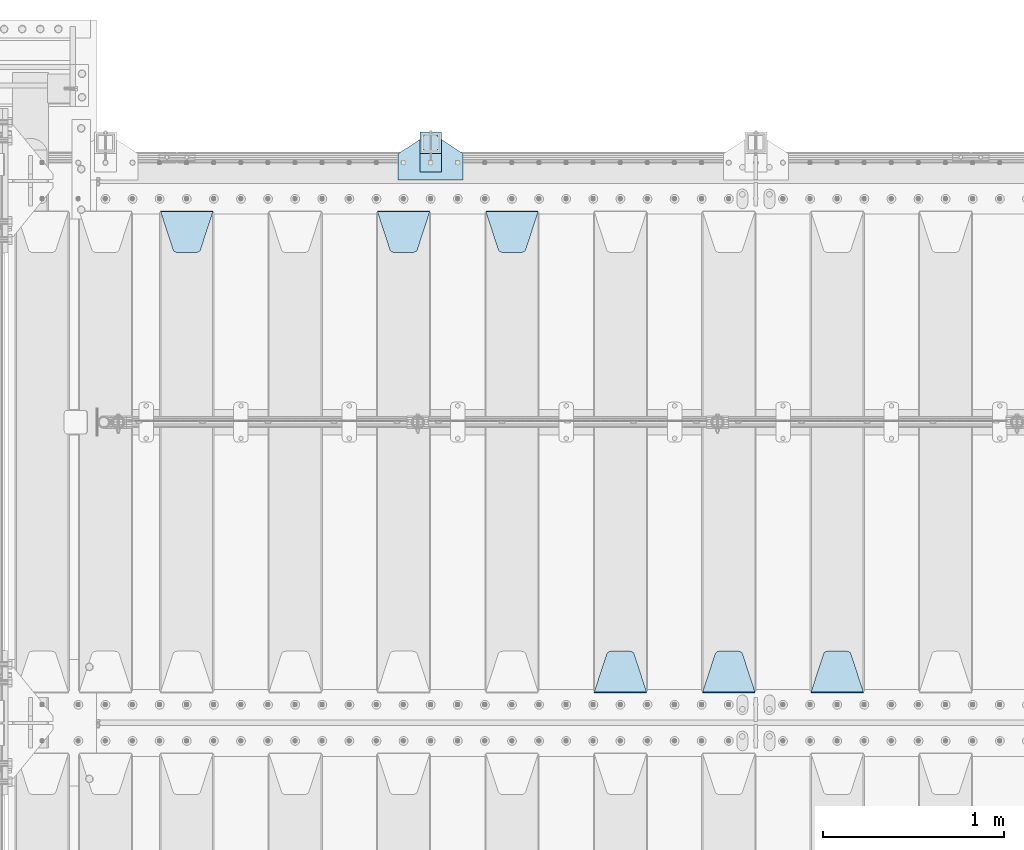
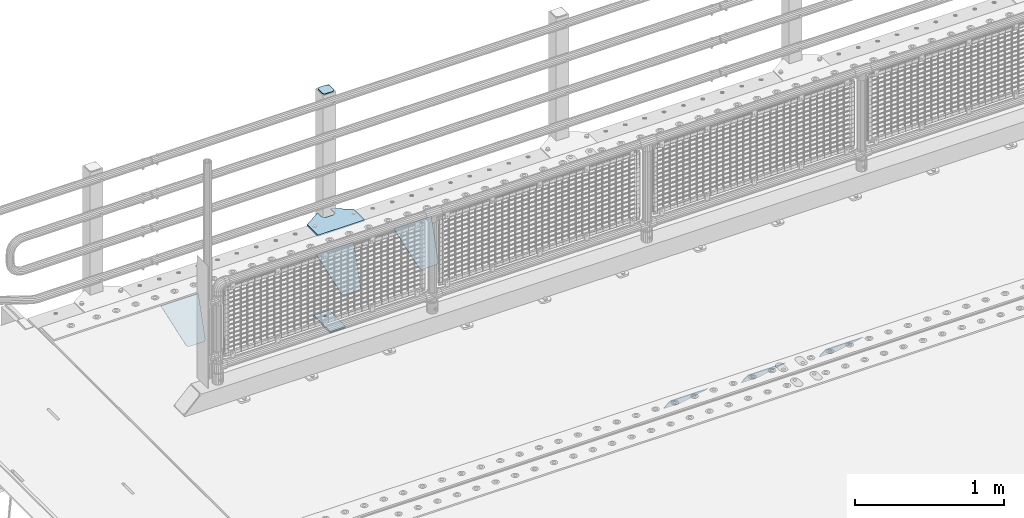
# One storey, part 160 of 193: 10 plates.
"""IFC2X3 building model written with IfcOpenShell, lengths in millimetres."""

from ifc_helpers import new_model, si_unit, frame, origin_with_axes, place, context, subcontext, project, spatial, faceted_brep, material, type_object, element, save


model = new_model("IFC2X3")

# Units and contexts
model_context = context("Model", 3, precision=1e-05, world=origin_with_axes())
body_context = subcontext(model_context, "Body", "Model", "MODEL_VIEW")
ifc_project = project(units=[si_unit("LENGTHUNIT", "METRE", prefix="MILLI"), si_unit("AREAUNIT", "SQUARE_METRE"), si_unit("VOLUMEUNIT", "CUBIC_METRE"), si_unit("MASSUNIT", "GRAM", prefix="KILO"), si_unit("TIMEUNIT", "SECOND"), si_unit("PLANEANGLEUNIT", "RADIAN"), si_unit("SOLIDANGLEUNIT", "STERADIAN"), si_unit("THERMODYNAMICTEMPERATUREUNIT", "DEGREE_CELSIUS"), si_unit("LUMINOUSINTENSITYUNIT", "LUMEN")], contexts=[model_context])

# Site, building, storey
site_placement = place(None, origin_with_axes())
site = spatial("IfcSite", under=ifc_project, at=site_placement, CompositionType="ELEMENT")
building_placement = place(site_placement, origin_with_axes())
building = spatial("IfcBuilding", under=site, at=building_placement, Name="Standard", CompositionType="ELEMENT")
storey_placement = place(building_placement, origin_with_axes())
storey = spatial("IfcBuildingStorey", under=building, at=storey_placement, Name="Undefined", CompositionType="ELEMENT", Elevation=0.0)

# Plates
ifc_material_1 = material(Name="STEEL/S355N")
plate_type_1 = type_object("IfcPlateType", PredefinedType="NOTDEFINED")
plate_1_placement = place(storey_placement, frame((-37705.0, 27168.232233047, -1.76776695296758), z_axis=(0.0, 0.707106781186547, -0.707106781186548), x_axis=(-1.0, 0.0, 0.0)))
element("IfcPlate", 1, at=plate_1_placement, inside=storey, type_object=plate_type_1, material=ifc_material_1, context=body_context, shape_type="Brep", body=[
    faceted_brep([(0.0, -2.5, 0.0), (69.345504679477, -2.50000000000364, 300.171731424831), (69.345504679477, 2.49999999999636, 300.171731424831), (0.0, 2.5, 0.0), (70.9274061199576, -2.50000000000364, 304.897442415397), (70.9274061199576, 2.49999999999636, 304.897442415397), (73.3818627772307, -2.50000000000364, 309.234538108529), (73.3818627772307, 2.49999999999636, 309.234538108529), (76.6187032999551, -2.50000000000728, 313.023683126103), (76.6187032999551, 2.49999999999636, 313.023683126103), (80.5190132704993, -2.50000000000364, 316.125672595372), (80.5190132704993, 2.49999999999636, 316.125672595368), (84.9395038596849, -2.50000000000364, 318.426546230472), (84.9395038596849, 2.49999999999636, 318.426546230476), (89.7177759439219, -2.50000000000364, 319.841774983273), (89.7177759439219, 2.49999999999636, 319.841774983277), (94.678286292652, -2.50000000000364, 320.319366455074), (94.678286292652, 2.49999999999636, 320.319366455074), (195.321713707348, -2.50000000000364, 320.319366455074), (195.321713707348, 2.49999999999636, 320.319366455074), (200.282224056078, -2.50000000000364, 319.841774983273), (200.282224056078, 2.49999999999636, 319.841774983277), (205.060496140315, -2.50000000000364, 318.426546230472), (205.060496140315, 2.49999999999636, 318.426546230472), (209.480986729501, -2.50000000000364, 316.125672595372), (209.480986729501, 2.49999999999636, 316.125672595368), (213.381296700045, -2.50000000000728, 313.023683126103), (213.381296700045, 2.49999999999272, 313.023683126103), (216.618137222769, -2.50000000000364, 309.234538108525), (216.618137222769, 2.49999999999636, 309.234538108522), (219.072593880042, -2.50000000000364, 304.897442415397), (219.072593880042, 2.49999999999636, 304.897442415397), (220.654495320523, -2.50000000000364, 300.171731424831), (220.654495320523, 2.49999999999636, 300.171731424831), (290.0, -2.50000000000364, 0.0), (290.0, 2.49999999999636, 0.0)], [[[0, 1, 2, 3]], [[1, 4, 5, 2]], [[4, 6, 7, 5]], [[6, 8, 9, 7]], [[8, 10, 11, 9]], [[10, 12, 13, 11]], [[12, 14, 15, 13]], [[14, 16, 17, 15]], [[16, 18, 19, 17]], [[18, 20, 21, 19]], [[20, 22, 23, 21]], [[22, 24, 25, 23]], [[24, 26, 27, 25]], [[26, 28, 29, 27]], [[28, 30, 31, 29]], [[30, 32, 33, 31]], [[32, 34, 35, 33]], [[34, 0, 3, 35]], [[5, 7, 9, 11, 13, 15, 17, 19, 21, 23, 25, 27, 29, 31, 33, 35, 3, 2]], [[34, 32, 30, 28, 26, 24, 22, 20, 18, 16, 14, 12, 10, 8, 6, 4, 1, 0]]]),
])
plate_2_placement = place(storey_placement, frame((-38305.0, 27168.232233047, -1.76776695296758), z_axis=(0.0, 0.707106781186547, -0.707106781186548), x_axis=(-1.0, 0.0, 0.0)))
element("IfcPlate", 2, at=plate_2_placement, inside=storey, type_object=plate_type_1, material=ifc_material_1, context=body_context, shape_type="Brep", body=[
    faceted_brep([(0.0, -2.5, 0.0), (69.345504679477, -2.50000000000364, 300.171731424831), (69.345504679477, 2.49999999999636, 300.171731424831), (0.0, 2.5, 0.0), (70.9274061199576, -2.50000000000364, 304.897442415397), (70.9274061199576, 2.49999999999636, 304.897442415397), (73.3818627772307, -2.50000000000364, 309.234538108529), (73.3818627772307, 2.49999999999636, 309.234538108529), (76.6187032999551, -2.50000000000728, 313.023683126103), (76.6187032999551, 2.49999999999636, 313.023683126103), (80.5190132704993, -2.50000000000364, 316.125672595372), (80.5190132704993, 2.49999999999636, 316.125672595368), (84.9395038596849, -2.50000000000364, 318.426546230472), (84.9395038596849, 2.49999999999636, 318.426546230476), (89.7177759439219, -2.50000000000364, 319.841774983273), (89.7177759439219, 2.49999999999636, 319.841774983277), (94.678286292652, -2.50000000000364, 320.319366455074), (94.678286292652, 2.49999999999636, 320.319366455074), (195.321713707348, -2.50000000000364, 320.319366455074), (195.321713707348, 2.49999999999636, 320.319366455074), (200.282224056078, -2.50000000000364, 319.841774983273), (200.282224056078, 2.49999999999636, 319.841774983277), (205.060496140315, -2.50000000000364, 318.426546230472), (205.060496140315, 2.49999999999636, 318.426546230472), (209.480986729501, -2.50000000000364, 316.125672595372), (209.480986729501, 2.49999999999636, 316.125672595368), (213.381296700045, -2.50000000000728, 313.023683126103), (213.381296700045, 2.49999999999272, 313.023683126103), (216.618137222769, -2.50000000000364, 309.234538108525), (216.618137222769, 2.49999999999636, 309.234538108522), (219.072593880042, -2.50000000000364, 304.897442415397), (219.072593880042, 2.49999999999636, 304.897442415397), (220.654495320523, -2.50000000000364, 300.171731424831), (220.654495320523, 2.49999999999636, 300.171731424831), (290.0, -2.50000000000364, 0.0), (290.0, 2.49999999999636, 0.0)], [[[0, 1, 2, 3]], [[1, 4, 5, 2]], [[4, 6, 7, 5]], [[6, 8, 9, 7]], [[8, 10, 11, 9]], [[10, 12, 13, 11]], [[12, 14, 15, 13]], [[14, 16, 17, 15]], [[16, 18, 19, 17]], [[18, 20, 21, 19]], [[20, 22, 23, 21]], [[22, 24, 25, 23]], [[24, 26, 27, 25]], [[26, 28, 29, 27]], [[28, 30, 31, 29]], [[30, 32, 33, 31]], [[32, 34, 35, 33]], [[34, 0, 3, 35]], [[5, 7, 9, 11, 13, 15, 17, 19, 21, 23, 25, 27, 29, 31, 33, 35, 3, 2]], [[34, 32, 30, 28, 26, 24, 22, 20, 18, 16, 14, 12, 10, 8, 6, 4, 1, 0]]]),
])
plate_3_placement = place(storey_placement, frame((-38905.0, 27168.232233047, -1.76776695296758), z_axis=(0.0, 0.707106781186547, -0.707106781186548), x_axis=(-1.0, 0.0, 0.0)))
element("IfcPlate", 3, at=plate_3_placement, inside=storey, type_object=plate_type_1, material=ifc_material_1, context=body_context, shape_type="Brep", body=[
    faceted_brep([(0.0, -2.5, 0.0), (69.345504679477, -2.50000000000364, 300.171731424831), (69.345504679477, 2.49999999999636, 300.171731424831), (0.0, 2.5, 0.0), (70.9274061199576, -2.50000000000364, 304.897442415397), (70.9274061199576, 2.49999999999636, 304.897442415397), (73.3818627772307, -2.50000000000364, 309.234538108529), (73.3818627772307, 2.49999999999636, 309.234538108529), (76.6187032999551, -2.50000000000728, 313.023683126103), (76.6187032999551, 2.49999999999636, 313.023683126103), (80.5190132704993, -2.50000000000364, 316.125672595372), (80.5190132704993, 2.49999999999636, 316.125672595368), (84.9395038596849, -2.50000000000364, 318.426546230472), (84.9395038596849, 2.49999999999636, 318.426546230476), (89.7177759439219, -2.50000000000364, 319.841774983273), (89.7177759439219, 2.49999999999636, 319.841774983277), (94.678286292652, -2.50000000000364, 320.319366455074), (94.678286292652, 2.49999999999636, 320.319366455074), (195.321713707348, -2.50000000000364, 320.319366455074), (195.321713707348, 2.49999999999636, 320.319366455074), (200.282224056078, -2.50000000000364, 319.841774983273), (200.282224056078, 2.49999999999636, 319.841774983277), (205.060496140315, -2.50000000000364, 318.426546230472), (205.060496140315, 2.49999999999636, 318.426546230472), (209.480986729501, -2.50000000000364, 316.125672595372), (209.480986729501, 2.49999999999636, 316.125672595368), (213.381296700045, -2.50000000000728, 313.023683126103), (213.381296700045, 2.49999999999272, 313.023683126103), (216.618137222769, -2.50000000000364, 309.234538108525), (216.618137222769, 2.49999999999636, 309.234538108522), (219.072593880042, -2.50000000000364, 304.897442415397), (219.072593880042, 2.49999999999636, 304.897442415397), (220.654495320523, -2.50000000000364, 300.171731424831), (220.654495320523, 2.49999999999636, 300.171731424831), (290.0, -2.50000000000364, 0.0), (290.0, 2.49999999999636, 0.0)], [[[0, 1, 2, 3]], [[1, 4, 5, 2]], [[4, 6, 7, 5]], [[6, 8, 9, 7]], [[8, 10, 11, 9]], [[10, 12, 13, 11]], [[12, 14, 15, 13]], [[14, 16, 17, 15]], [[16, 18, 19, 17]], [[18, 20, 21, 19]], [[20, 22, 23, 21]], [[22, 24, 25, 23]], [[24, 26, 27, 25]], [[26, 28, 29, 27]], [[28, 30, 31, 29]], [[30, 32, 33, 31]], [[32, 34, 35, 33]], [[34, 0, 3, 35]], [[5, 7, 9, 11, 13, 15, 17, 19, 21, 23, 25, 27, 29, 31, 33, 35, 3, 2]], [[34, 32, 30, 28, 26, 24, 22, 20, 18, 16, 14, 12, 10, 8, 6, 4, 1, 0]]]),
])
plate_4_placement = place(storey_placement, frame((-39795.0, 29831.767766956, -1.76776695296758), z_axis=(0.0, -0.707106781186547, -0.707106781186548), x_axis=(1.0, 0.0, 0.0)))
element("IfcPlate", 4, at=plate_4_placement, inside=storey, type_object=plate_type_1, material=ifc_material_1, context=body_context, shape_type="Brep", body=[
    faceted_brep([(0.0, -2.5, 0.0), (69.345504679477, -2.50000000000364, 300.171731424831), (69.345504679477, 2.49999999999636, 300.171731424831), (0.0, 2.5, 0.0), (70.9274061199576, -2.50000000000364, 304.897442415397), (70.9274061199576, 2.49999999999636, 304.897442415397), (73.3818627772307, -2.50000000000364, 309.234538108529), (73.3818627772307, 2.49999999999636, 309.234538108529), (76.6187032999551, -2.50000000000728, 313.023683126103), (76.6187032999551, 2.49999999999636, 313.023683126103), (80.5190132704993, -2.50000000000364, 316.125672595372), (80.5190132704993, 2.49999999999636, 316.125672595368), (84.9395038596849, -2.50000000000364, 318.426546230472), (84.9395038596849, 2.49999999999636, 318.426546230476), (89.7177759439219, -2.50000000000364, 319.841774983273), (89.7177759439219, 2.49999999999636, 319.841774983277), (94.678286292652, -2.50000000000364, 320.319366455074), (94.678286292652, 2.49999999999636, 320.319366455074), (195.321713707348, -2.50000000000364, 320.319366455074), (195.321713707348, 2.49999999999636, 320.319366455074), (200.282224056078, -2.50000000000364, 319.841774983273), (200.282224056078, 2.49999999999636, 319.841774983277), (205.060496140315, -2.50000000000364, 318.426546230472), (205.060496140315, 2.49999999999636, 318.426546230472), (209.480986729501, -2.50000000000364, 316.125672595372), (209.480986729501, 2.49999999999636, 316.125672595368), (213.381296700045, -2.50000000000728, 313.023683126103), (213.381296700045, 2.49999999999272, 313.023683126103), (216.618137222769, -2.50000000000364, 309.234538108525), (216.618137222769, 2.49999999999636, 309.234538108522), (219.072593880042, -2.50000000000364, 304.897442415397), (219.072593880042, 2.49999999999636, 304.897442415397), (220.654495320523, -2.50000000000364, 300.171731424831), (220.654495320523, 2.49999999999636, 300.171731424831), (290.0, -2.50000000000364, 0.0), (290.0, 2.49999999999636, 0.0)], [[[0, 1, 2, 3]], [[1, 4, 5, 2]], [[4, 6, 7, 5]], [[6, 8, 9, 7]], [[8, 10, 11, 9]], [[10, 12, 13, 11]], [[12, 14, 15, 13]], [[14, 16, 17, 15]], [[16, 18, 19, 17]], [[18, 20, 21, 19]], [[20, 22, 23, 21]], [[22, 24, 25, 23]], [[24, 26, 27, 25]], [[26, 28, 29, 27]], [[28, 30, 31, 29]], [[30, 32, 33, 31]], [[32, 34, 35, 33]], [[34, 0, 3, 35]], [[5, 7, 9, 11, 13, 15, 17, 19, 21, 23, 25, 27, 29, 31, 33, 35, 3, 2]], [[34, 32, 30, 28, 26, 24, 22, 20, 18, 16, 14, 12, 10, 8, 6, 4, 1, 0]]]),
])
plate_5_placement = place(storey_placement, frame((-40395.0, 29831.767766956, -1.76776695296758), z_axis=(0.0, -0.707106781186547, -0.707106781186548), x_axis=(1.0, 0.0, 0.0)))
element("IfcPlate", 5, at=plate_5_placement, inside=storey, type_object=plate_type_1, material=ifc_material_1, context=body_context, shape_type="Brep", body=[
    faceted_brep([(0.0, -2.5, 0.0), (69.345504679477, -2.50000000000364, 300.171731424831), (69.345504679477, 2.49999999999636, 300.171731424831), (0.0, 2.5, 0.0), (70.9274061199576, -2.50000000000364, 304.897442415397), (70.9274061199576, 2.49999999999636, 304.897442415397), (73.3818627772307, -2.50000000000364, 309.234538108529), (73.3818627772307, 2.49999999999636, 309.234538108529), (76.6187032999551, -2.50000000000728, 313.023683126103), (76.6187032999551, 2.49999999999636, 313.023683126103), (80.5190132704993, -2.50000000000364, 316.125672595372), (80.5190132704993, 2.49999999999636, 316.125672595368), (84.9395038596849, -2.50000000000364, 318.426546230472), (84.9395038596849, 2.49999999999636, 318.426546230476), (89.7177759439219, -2.50000000000364, 319.841774983273), (89.7177759439219, 2.49999999999636, 319.841774983277), (94.678286292652, -2.50000000000364, 320.319366455074), (94.678286292652, 2.49999999999636, 320.319366455074), (195.321713707348, -2.50000000000364, 320.319366455074), (195.321713707348, 2.49999999999636, 320.319366455074), (200.282224056078, -2.50000000000364, 319.841774983273), (200.282224056078, 2.49999999999636, 319.841774983277), (205.060496140315, -2.50000000000364, 318.426546230472), (205.060496140315, 2.49999999999636, 318.426546230472), (209.480986729501, -2.50000000000364, 316.125672595372), (209.480986729501, 2.49999999999636, 316.125672595368), (213.381296700045, -2.50000000000728, 313.023683126103), (213.381296700045, 2.49999999999272, 313.023683126103), (216.618137222769, -2.50000000000364, 309.234538108525), (216.618137222769, 2.49999999999636, 309.234538108522), (219.072593880042, -2.50000000000364, 304.897442415397), (219.072593880042, 2.49999999999636, 304.897442415397), (220.654495320523, -2.50000000000364, 300.171731424831), (220.654495320523, 2.49999999999636, 300.171731424831), (290.0, -2.50000000000364, 0.0), (290.0, 2.49999999999636, 0.0)], [[[0, 1, 2, 3]], [[1, 4, 5, 2]], [[4, 6, 7, 5]], [[6, 8, 9, 7]], [[8, 10, 11, 9]], [[10, 12, 13, 11]], [[12, 14, 15, 13]], [[14, 16, 17, 15]], [[16, 18, 19, 17]], [[18, 20, 21, 19]], [[20, 22, 23, 21]], [[22, 24, 25, 23]], [[24, 26, 27, 25]], [[26, 28, 29, 27]], [[28, 30, 31, 29]], [[30, 32, 33, 31]], [[32, 34, 35, 33]], [[34, 0, 3, 35]], [[5, 7, 9, 11, 13, 15, 17, 19, 21, 23, 25, 27, 29, 31, 33, 35, 3, 2]], [[34, 32, 30, 28, 26, 24, 22, 20, 18, 16, 14, 12, 10, 8, 6, 4, 1, 0]]]),
])
plate_6_placement = place(storey_placement, frame((-41595.0, 29831.767766956, -1.76776695296758), z_axis=(0.0, -0.707106781186547, -0.707106781186548), x_axis=(1.0, 0.0, 0.0)))
element("IfcPlate", 6, at=plate_6_placement, inside=storey, type_object=plate_type_1, material=ifc_material_1, context=body_context, shape_type="Brep", body=[
    faceted_brep([(0.0, -2.5, 0.0), (69.345504679477, -2.50000000000364, 300.171731424831), (69.345504679477, 2.49999999999636, 300.171731424831), (0.0, 2.5, 0.0), (70.9274061199576, -2.50000000000364, 304.897442415397), (70.9274061199576, 2.49999999999636, 304.897442415397), (73.3818627772307, -2.50000000000364, 309.234538108529), (73.3818627772307, 2.49999999999636, 309.234538108529), (76.6187032999551, -2.50000000000728, 313.023683126103), (76.6187032999551, 2.49999999999636, 313.023683126103), (80.5190132704993, -2.50000000000364, 316.125672595372), (80.5190132704993, 2.49999999999636, 316.125672595368), (84.9395038596849, -2.50000000000364, 318.426546230472), (84.9395038596849, 2.49999999999636, 318.426546230476), (89.7177759439219, -2.50000000000364, 319.841774983273), (89.7177759439219, 2.49999999999636, 319.841774983277), (94.678286292652, -2.50000000000364, 320.319366455074), (94.678286292652, 2.49999999999636, 320.319366455074), (195.321713707348, -2.50000000000364, 320.319366455074), (195.321713707348, 2.49999999999636, 320.319366455074), (200.282224056078, -2.50000000000364, 319.841774983273), (200.282224056078, 2.49999999999636, 319.841774983277), (205.060496140315, -2.50000000000364, 318.426546230472), (205.060496140315, 2.49999999999636, 318.426546230472), (209.480986729501, -2.50000000000364, 316.125672595372), (209.480986729501, 2.49999999999636, 316.125672595368), (213.381296700045, -2.50000000000728, 313.023683126103), (213.381296700045, 2.49999999999272, 313.023683126103), (216.618137222769, -2.50000000000364, 309.234538108525), (216.618137222769, 2.49999999999636, 309.234538108522), (219.072593880042, -2.50000000000364, 304.897442415397), (219.072593880042, 2.49999999999636, 304.897442415397), (220.654495320523, -2.50000000000364, 300.171731424831), (220.654495320523, 2.49999999999636, 300.171731424831), (290.0, -2.50000000000364, 0.0), (290.0, 2.49999999999636, 0.0)], [[[0, 1, 2, 3]], [[1, 4, 5, 2]], [[4, 6, 7, 5]], [[6, 8, 9, 7]], [[8, 10, 11, 9]], [[10, 12, 13, 11]], [[12, 14, 15, 13]], [[14, 16, 17, 15]], [[16, 18, 19, 17]], [[18, 20, 21, 19]], [[20, 22, 23, 21]], [[22, 24, 25, 23]], [[24, 26, 27, 25]], [[26, 28, 29, 27]], [[28, 30, 31, 29]], [[30, 32, 33, 31]], [[32, 34, 35, 33]], [[34, 0, 3, 35]], [[5, 7, 9, 11, 13, 15, 17, 19, 21, 23, 25, 27, 29, 31, 33, 35, 3, 2]], [[34, 32, 30, 28, 26, 24, 22, 20, 18, 16, 14, 12, 10, 8, 6, 4, 1, 0]]]),
])
ifc_material_2 = material(Name="STEEL/S355J2")
plate_type_2 = type_object("IfcPlateType", PredefinedType="NOTDEFINED")
plate_7_placement = place(storey_placement, frame((-40280.0, 30005.0, 5.00000000004911), z_axis=(0.0, 1.0, 0.0), x_axis=(1.0, 0.0, 0.0)))
element("IfcPlate", 7, at=plate_7_placement, inside=storey, type_object=plate_type_2, material=ifc_material_2, context=body_context, shape_type="Brep", body=[
    faceted_brep([(0.0, -5.0, 0.0), (2.31396552408114e-06, -5.0, 145.0), (2.31396552408114e-06, 5.0, 145.0), (0.0, 5.0, 0.0), (130.0, -5.0, 230.0), (130.0, 5.0, 230.0), (130.0, -5.0, 180.0), (130.0, 5.0, 180.0), (130.48036798992, -5.0, 175.122741949595), (130.48036798992, 5.0, 175.122741949595), (131.903011687216, -5.0, 170.432914190871), (131.903011687216, 5.0, 170.432914190871), (134.213259692435, -5.0, 166.110744174512), (134.213259692435, 5.0, 166.110744174512), (137.322330470335, -5.0, 162.322330470335), (137.322330470335, 5.0, 162.322330470335), (141.110744174512, -5.0, 159.213259692435), (141.110744174512, 5.0, 159.213259692435), (145.432914190871, -5.0, 156.903011687216), (145.432914190871, 5.0, 156.903011687216), (150.122741949595, -5.0, 155.48036798992), (150.122741949595, 5.0, 155.48036798992), (155.0, -5.0, 155.0), (155.0, 5.0, 155.0), (205.0, -5.0, 155.0), (205.0, 5.0, 155.0), (209.877258050405, -5.0, 155.48036798992), (209.877258050405, 5.0, 155.48036798992), (214.567085809129, -5.0, 156.903011687216), (214.567085809129, 5.0, 156.903011687216), (218.889255825488, -5.0, 159.213259692435), (218.889255825488, 5.0, 159.213259692435), (222.677669529665, -5.0, 162.322330470335), (222.677669529665, 5.0, 162.322330470335), (225.786740307565, -5.0, 166.110744174512), (225.786740307565, 5.0, 166.110744174512), (228.096988312784, -5.0, 170.432914190871), (228.096988312784, 5.0, 170.432914190871), (229.51963201008, -5.0, 175.122741949595), (229.51963201008, 5.0, 175.122741949595), (230.0, -5.0, 180.0), (230.0, 5.0, 180.0), (230.0, -5.0, 230.0), (230.0, 5.0, 230.0), (360.0, -5.0, 145.0), (360.0, 5.0, 145.0), (360.0, -5.0, -7.27595761418343e-12), (360.0, 5.0, -7.27595761418343e-12)], [[[0, 1, 2, 3]], [[1, 4, 5, 2]], [[4, 6, 7, 5]], [[6, 8, 9, 7]], [[8, 10, 11, 9]], [[10, 12, 13, 11]], [[12, 14, 15, 13]], [[14, 16, 17, 15]], [[16, 18, 19, 17]], [[18, 20, 21, 19]], [[20, 22, 23, 21]], [[22, 24, 25, 23]], [[24, 26, 27, 25]], [[26, 28, 29, 27]], [[28, 30, 31, 29]], [[30, 32, 33, 31]], [[32, 34, 35, 33]], [[34, 36, 37, 35]], [[36, 38, 39, 37]], [[38, 40, 41, 39]], [[40, 42, 43, 41]], [[42, 44, 45, 43]], [[44, 46, 47, 45]], [[46, 0, 3, 47]], [[5, 7, 9, 11, 13, 15, 17, 19, 21, 23, 25, 27, 29, 31, 33, 35, 37, 39, 41, 43, 45, 47, 3, 2]], [[46, 44, 42, 40, 38, 36, 34, 32, 30, 28, 26, 24, 22, 20, 18, 16, 14, 12, 10, 8, 6, 4, 1, 0]]]),
])
plate_type_3 = type_object("IfcPlateType", PredefinedType="NOTDEFINED")
plate_8_placement = place(storey_placement, frame((-40159.9999999999, 30050.0000000002, -850.000000000002), z_axis=(0.0, 1.0, 0.0), x_axis=(1.0, 0.0, 0.0)))
element("IfcPlate", 8, at=plate_8_placement, inside=storey, type_object=plate_type_3, material=ifc_material_2, context=body_context, shape_type="Brep", body=[
    faceted_brep([(66.3639610305399, -5.0, 163.636038969111), (66.3639610305399, 5.0, 163.636038969111), (59.9999999998618, 5.0, 160.999999999789), (59.9999999998618, -5.0, 160.999999999789), (53.6360389691836, 5.0, 163.636038969111), (53.6360389691836, -5.0, 163.636038969111), (50.9999999998618, 5.0, 169.999999999789), (50.9999999998618, -5.0, 169.999999999789), (53.6360389691836, 5.0, 176.363961030467), (53.6360389691836, -5.0, 176.363961030467), (59.9999999998618, 5.0, 178.999999999789), (59.9999999998618, -5.0, 178.999999999789), (66.3639610305399, 5.0, 176.363961030467), (66.3639610305399, -5.0, 176.363961030467), (68.9999999998618, 5.0, 169.999999999789), (68.9999999998618, -5.0, 169.999999999789), (120.0, -5.0, 0.0), (120.0, -5.0, 220.0), (0.0, -5.0, 220.0), (0.0, -5.0, 0.0), (0.0, 5.0, 0.0), (120.0, 5.0, 0.0), (120.0, 5.0, 220.0), (0.0, 5.0, 220.0)], [[[0, 1, 2, 3]], [[3, 2, 4, 5]], [[5, 4, 6, 7]], [[7, 6, 8, 9]], [[9, 8, 10, 11]], [[11, 10, 12, 13]], [[13, 12, 14, 15]], [[15, 14, 1, 0]], [[16, 17, 18, 19], [3, 5, 7, 9, 11, 13, 15, 0]], [[16, 19, 20, 21]], [[17, 16, 21, 22]], [[18, 17, 22, 23]], [[19, 18, 23, 20]], [[22, 21, 20, 23], [10, 8, 6, 4, 2, 1, 14, 12]]]),
])
plate_type_4 = type_object("IfcPlateType", PredefinedType="NOTDEFINED")
plate_9_placement = place(storey_placement, frame((-40055.9999999999, 30166.0000000002, 1012.50000000001), z_axis=(0.0, 1.0, 0.0), x_axis=(-1.0, 0.0, 0.0)))
element("IfcPlate", 9, at=plate_9_placement, inside=storey, type_object=plate_type_4, material=ifc_material_2, context=body_context, shape_type="Brep", body=[
    faceted_brep([(0.0, -2.5, 19.0), (0.0, -2.5, 69.0), (0.0, 2.5, 69.0), (0.0, 2.5, 19.0), (0.476369668544066, -2.5, 73.2278977451715), (0.476369668544066, 2.5, 73.2278977451715), (1.88159150985302, -2.5, 77.2437910432345), (1.88159150985302, 2.5, 77.2437910432345), (4.14520183310742, -2.5, 80.8463062353148), (4.14520183310742, 2.5, 80.8463062353148), (7.15369376468516, -2.5, 83.8547981668926), (7.15369376468516, 2.5, 83.8547981668926), (10.7562089567655, -2.5, 86.118408490147), (10.7562089567655, 2.5, 86.118408490147), (14.7721022548285, -2.5, 87.5236303314559), (14.7721022548285, 2.5, 87.5236303314559), (19.0, -2.5, 88.0), (19.0, 2.5, 88.0), (69.0, -2.5, 88.0), (69.0, 2.5, 88.0), (73.2278977451715, -2.5, 87.5236303314559), (73.2278977451715, 2.5, 87.5236303314559), (77.2437910432345, -2.5, 86.118408490147), (77.2437910432345, 2.5, 86.118408490147), (80.8463062353148, -2.5, 83.8547981668926), (80.8463062353148, 2.5, 83.8547981668926), (83.8547981668926, -2.5, 80.8463062353148), (83.8547981668926, 2.5, 80.8463062353148), (86.118408490147, -2.5, 77.2437910432345), (86.118408490147, 2.5, 77.2437910432345), (87.5236303314559, -2.5, 73.2278977451715), (87.5236303314559, 2.5, 73.2278977451715), (88.0, -2.5, 69.0), (88.0, 2.5, 69.0), (88.0, -2.5, 19.0), (88.0, 2.5, 19.0), (87.5236303314559, -2.5, 14.7721022548285), (87.5236303314559, 2.5, 14.7721022548285), (86.118408490147, -2.5, 10.7562089567655), (86.118408490147, 2.5, 10.7562089567655), (83.8547981668926, -2.5, 7.15369376468516), (83.8547981668926, 2.5, 7.15369376468516), (80.8463062353148, -2.5, 4.14520183310742), (80.8463062353148, 2.5, 4.14520183310742), (77.2437910432345, -2.5, 1.88159150985302), (77.2437910432345, 2.5, 1.88159150985302), (73.2278977451715, -2.5, 0.476369668544066), (73.2278977451715, 2.5, 0.476369668544066), (69.0, -2.5, 0.0), (69.0, 2.5, 0.0), (19.0, -2.5, 0.0), (19.0, 2.5, 0.0), (14.7721022548285, -2.5, 0.476369668544066), (14.7721022548285, 2.5, 0.476369668544066), (10.7562089567655, -2.5, 1.88159150985302), (10.7562089567655, 2.5, 1.88159150985302), (7.15369376468516, -2.5, 4.14520183310742), (7.15369376468516, 2.5, 4.14520183310742), (4.14520183310742, -2.5, 7.15369376468516), (4.14520183310742, 2.5, 7.15369376468516), (1.88159150985302, -2.5, 10.7562089567655), (1.88159150985302, 2.5, 10.7562089567655), (0.476369668544066, -2.5, 14.7721022548285), (0.476369668544066, 2.5, 14.7721022548285)], [[[0, 1, 2, 3]], [[1, 4, 5, 2]], [[4, 6, 7, 5]], [[6, 8, 9, 7]], [[8, 10, 11, 9]], [[10, 12, 13, 11]], [[12, 14, 15, 13]], [[14, 16, 17, 15]], [[16, 18, 19, 17]], [[18, 20, 21, 19]], [[20, 22, 23, 21]], [[22, 24, 25, 23]], [[24, 26, 27, 25]], [[26, 28, 29, 27]], [[28, 30, 31, 29]], [[30, 32, 33, 31]], [[32, 34, 35, 33]], [[34, 36, 37, 35]], [[36, 38, 39, 37]], [[38, 40, 41, 39]], [[40, 42, 43, 41]], [[42, 44, 45, 43]], [[44, 46, 47, 45]], [[46, 48, 49, 47]], [[48, 50, 51, 49]], [[50, 52, 53, 51]], [[52, 54, 55, 53]], [[54, 56, 57, 55]], [[56, 58, 59, 57]], [[58, 60, 61, 59]], [[60, 62, 63, 61]], [[62, 0, 3, 63]], [[5, 7, 9, 11, 13, 15, 17, 19, 21, 23, 25, 27, 29, 31, 33, 35, 37, 39, 41, 43, 45, 47, 49, 51, 53, 55, 57, 59, 61, 63, 3, 2]], [[62, 60, 58, 56, 54, 52, 50, 48, 46, 44, 42, 40, 38, 36, 34, 32, 30, 28, 26, 24, 22, 20, 18, 16, 14, 12, 10, 8, 6, 4, 1, 0]]]),
])
plate_type_5 = type_object("IfcPlateType", PredefinedType="NOTDEFINED")
plate_10_placement = place(storey_placement, frame((-40159.9999999999, 30050.0000000002, -857.500000000002), z_axis=(0.0, 1.0, 0.0), x_axis=(1.0, 0.0, 0.0)))
element("IfcPlate", 10, at=plate_10_placement, inside=storey, type_object=plate_type_5, material=ifc_material_2, context=body_context, shape_type="Brep", body=[
    faceted_brep([(0.0, -2.5, 0.0), (0.0, -2.5, 100.0), (0.0, 2.5, 100.0), (0.0, 2.5, 0.0), (120.0, -2.5, 100.0), (120.0, 2.5, 100.0), (120.0, -2.5, 0.0), (120.0, 2.5, 0.0)], [[[0, 1, 2, 3]], [[1, 4, 5, 2]], [[4, 6, 7, 5]], [[6, 0, 3, 7]], [[5, 7, 3, 2]], [[6, 4, 1, 0]]]),
])

save(model, "model.ifc")
